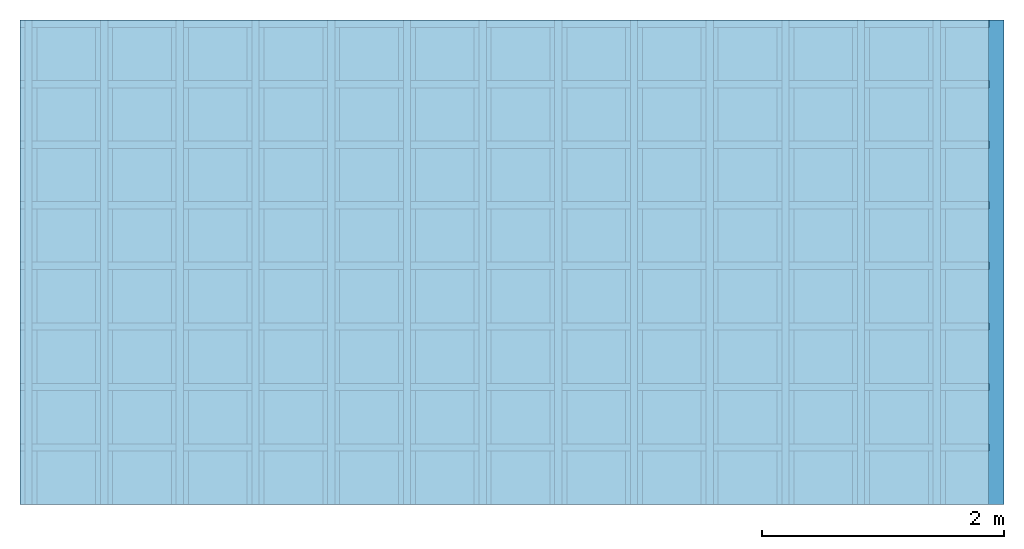
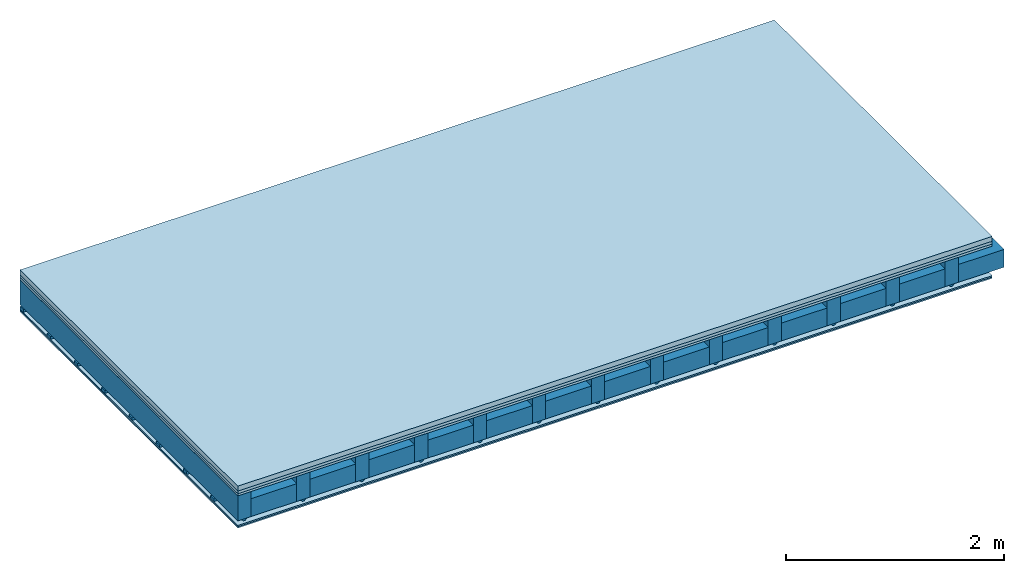
# One storey: 5 plates, 4 members, 1 element without a shape of its own.
"""IFC4 building model written with IfcOpenShell, lengths in metres."""

from ifc_helpers import new_model, si_unit, derived_unit, direction, frame, frame_2d, origin, origin_with_axes, place, context, project, spatial, polyline, rectangle, outline, extrude, material, layer, layer_set, type_object, element, aggregate, save


model = new_model("IFC4")

# Units and contexts
plan_context = context("Plan", 3, precision=1e-05, world=origin(), true_north=direction((0.0, 1.0)))
model_context = context("Model", 3, precision=1e-05, world=origin(), true_north=direction((0.0, 1.0)))
ifc_project = project(units=[si_unit("LENGTHUNIT", "METRE"), derived_unit("SOUNDPRESSUREUNIT", [(si_unit("PRESSUREUNIT", "PASCAL", prefix="MICRO"), 0)]), si_unit("ENERGYUNIT", "JOULE", prefix="MEGA"), si_unit("MASSUNIT", "GRAM", prefix="KILO"), derived_unit("THERMALTRANSMITTANCEUNIT", [(si_unit("POWERUNIT", "WATT"), 1), (si_unit("AREAUNIT", "SQUARE_METRE"), -1), (si_unit("THERMODYNAMICTEMPERATUREUNIT", "KELVIN"), -1)]), derived_unit("AREADENSITYUNIT", [(si_unit("MASSUNIT", "GRAM", prefix="KILO"), 1), (si_unit("AREAUNIT", "SQUARE_METRE"), -1)]), derived_unit("USERDEFINED", [(si_unit("ENERGYUNIT", "JOULE", prefix="MEGA"), 1), (si_unit("AREAUNIT", "SQUARE_METRE"), -1)])], contexts=[plan_context, model_context])

# Site, building, storey
site = spatial("IfcSite", under=ifc_project)
building_placement = place(None, origin())
building = spatial("IfcBuilding", under=site, at=building_placement)
storey_placement = place(building_placement, origin())
storey = spatial("IfcBuildingStorey", under=building, at=storey_placement)

# Slab, members, plates
ifc_material_1 = material(Category="04.005")
ifc_layer_1 = layer(ifc_material_1, 0.055, Name="On-material")
ifc_material_2 = material()
ifc_layer_2 = layer(ifc_material_2, 0.03, Name="Impact sound insulation")
ifc_material_3 = material(Category="07.001")
ifc_layer_3 = layer(ifc_material_3, 0.025, Name="Sub-floor")
ifc_material_4 = material(Name="of the art")
ifc_layer_4 = layer(ifc_material_4, 0.0, Name="Bond")
ifc_layer_5 = layer(None, 0.28, Name="Supporting structure")
ifc_material_5 = material(Name="no composite action")
ifc_layer_6 = layer(ifc_material_5, 0.0, Name="Bond")
ifc_layer_7 = layer(None, 0.02, Name="Coupling")
ifc_layer_8 = layer(None, 0.03, Name="Battens / profiles")
ifc_material_6 = material(Category="03.007")
ifc_layer_9 = layer(ifc_material_6, 0.015, Name="Ceiling covering 1st layer")
ifc_layer_10 = layer(ifc_material_6, 0.015, Name="Ceiling covering layer 2")
ifc_material_7 = material(Name="Glued joints")
ifc_layer_11 = layer(ifc_material_7, 0.0, Name="Surface / treatment")
ifc_layer_set = layer_set([ifc_layer_1, ifc_layer_2, ifc_layer_3, ifc_layer_4, ifc_layer_5, ifc_layer_6, ifc_layer_7, ifc_layer_8, ifc_layer_9, ifc_layer_10, ifc_layer_11])
slab_type = type_object("IfcSlabType", Name="A0127", PredefinedType="NOTDEFINED", material=ifc_layer_set)
slab_placement = place(None, frame((0.0, 0.0, 0.0), z_axis=(0.0, 0.0, -1.0), x_axis=(1.0, 0.0, 0.0)))
slab = element("IfcSlab", 1, at=slab_placement, inside=storey, type_object=slab_type, material=ifc_layer_set, Name="Slab #1")
ifc_material_8 = material()
member_1_placement = place(slab_placement, origin())
member_1 = element("IfcMember", 2, at=member_1_placement, material=ifc_material_8, Name="Supporting structure", context=plan_context, shape_type="SweptSolid", body=[
    extrude(rectangle(XDim=0.14, YDim=0.28, at=frame_2d((0.07, 0.14), x_axis=(1.0, 0.0))), frame((0.0, 4.0, 0.11), z_axis=(0.0, -1.0, 0.0), x_axis=(1.0, 0.0, 0.0)), (0.0, 0.0, 1.0), 4.0),
    extrude(rectangle(XDim=0.14, YDim=0.28, at=frame_2d((0.07, 0.14), x_axis=(1.0, 0.0))), frame((0.625, 4.0, 0.11), z_axis=(0.0, -1.0, 0.0), x_axis=(1.0, 0.0, 0.0)), (0.0, 0.0, 1.0), 4.0),
    extrude(rectangle(XDim=0.14, YDim=0.28, at=frame_2d((0.07, 0.14), x_axis=(1.0, 0.0))), frame((1.25, 4.0, 0.11), z_axis=(0.0, -1.0, 0.0), x_axis=(1.0, 0.0, 0.0)), (0.0, 0.0, 1.0), 4.0),
    extrude(rectangle(XDim=0.14, YDim=0.28, at=frame_2d((0.07, 0.14), x_axis=(1.0, 0.0))), frame((1.875, 4.0, 0.11), z_axis=(0.0, -1.0, 0.0), x_axis=(1.0, 0.0, 0.0)), (0.0, 0.0, 1.0), 4.0),
    extrude(rectangle(XDim=0.14, YDim=0.28, at=frame_2d((0.07, 0.14), x_axis=(1.0, 0.0))), frame((2.5, 4.0, 0.11), z_axis=(0.0, -1.0, 0.0), x_axis=(1.0, 0.0, 0.0)), (0.0, 0.0, 1.0), 4.0),
    extrude(rectangle(XDim=0.14, YDim=0.28, at=frame_2d((0.07, 0.14), x_axis=(1.0, 0.0))), frame((3.125, 4.0, 0.11), z_axis=(0.0, -1.0, 0.0), x_axis=(1.0, 0.0, 0.0)), (0.0, 0.0, 1.0), 4.0),
    extrude(rectangle(XDim=0.14, YDim=0.28, at=frame_2d((0.07, 0.14), x_axis=(1.0, 0.0))), frame((3.75, 4.0, 0.11), z_axis=(0.0, -1.0, 0.0), x_axis=(1.0, 0.0, 0.0)), (0.0, 0.0, 1.0), 4.0),
    extrude(rectangle(XDim=0.14, YDim=0.28, at=frame_2d((0.07, 0.14), x_axis=(1.0, 0.0))), frame((4.375, 4.0, 0.11), z_axis=(0.0, -1.0, 0.0), x_axis=(1.0, 0.0, 0.0)), (0.0, 0.0, 1.0), 4.0),
    extrude(rectangle(XDim=0.14, YDim=0.28, at=frame_2d((0.07, 0.14), x_axis=(1.0, 0.0))), frame((5.0, 4.0, 0.11), z_axis=(0.0, -1.0, 0.0), x_axis=(1.0, 0.0, 0.0)), (0.0, 0.0, 1.0), 4.0),
    extrude(rectangle(XDim=0.14, YDim=0.28, at=frame_2d((0.07, 0.14), x_axis=(1.0, 0.0))), frame((5.625, 4.0, 0.11), z_axis=(0.0, -1.0, 0.0), x_axis=(1.0, 0.0, 0.0)), (0.0, 0.0, 1.0), 4.0),
    extrude(rectangle(XDim=0.14, YDim=0.28, at=frame_2d((0.07, 0.14), x_axis=(1.0, 0.0))), frame((6.25, 4.0, 0.11), z_axis=(0.0, -1.0, 0.0), x_axis=(1.0, 0.0, 0.0)), (0.0, 0.0, 1.0), 4.0),
    extrude(rectangle(XDim=0.14, YDim=0.28, at=frame_2d((0.07, 0.14), x_axis=(1.0, 0.0))), frame((6.875, 4.0, 0.11), z_axis=(0.0, -1.0, 0.0), x_axis=(1.0, 0.0, 0.0)), (0.0, 0.0, 1.0), 4.0),
    extrude(rectangle(XDim=0.14, YDim=0.28, at=frame_2d((0.07, 0.14), x_axis=(1.0, 0.0))), frame((7.5, 4.0, 0.11), z_axis=(0.0, -1.0, 0.0), x_axis=(1.0, 0.0, 0.0)), (0.0, 0.0, 1.0), 4.0),
])
ifc_material_9 = material()
member_2_placement = place(slab_placement, origin())
member_2 = element("IfcMember", 3, at=member_2_placement, material=ifc_material_9, Name="Cavity", context=plan_context, shape_type="SweptSolid", body=[
    extrude(rectangle(XDim=0.485, YDim=0.2, at=frame_2d((0.2425, 0.1), x_axis=(1.0, 0.0))), frame((0.14, 4.0, 0.19), z_axis=(0.0, -1.0, 0.0), x_axis=(1.0, 0.0, 0.0)), (0.0, 0.0, 1.0), 4.0),
    extrude(rectangle(XDim=0.485, YDim=0.2, at=frame_2d((0.2425, 0.1), x_axis=(1.0, 0.0))), frame((0.765, 4.0, 0.19), z_axis=(0.0, -1.0, 0.0), x_axis=(1.0, 0.0, 0.0)), (0.0, 0.0, 1.0), 4.0),
    extrude(rectangle(XDim=0.485, YDim=0.2, at=frame_2d((0.2425, 0.1), x_axis=(1.0, 0.0))), frame((1.39, 4.0, 0.19), z_axis=(0.0, -1.0, 0.0), x_axis=(1.0, 0.0, 0.0)), (0.0, 0.0, 1.0), 4.0),
    extrude(rectangle(XDim=0.485, YDim=0.2, at=frame_2d((0.2425, 0.1), x_axis=(1.0, 0.0))), frame((2.015, 4.0, 0.19), z_axis=(0.0, -1.0, 0.0), x_axis=(1.0, 0.0, 0.0)), (0.0, 0.0, 1.0), 4.0),
    extrude(rectangle(XDim=0.485, YDim=0.2, at=frame_2d((0.2425, 0.1), x_axis=(1.0, 0.0))), frame((2.64, 4.0, 0.19), z_axis=(0.0, -1.0, 0.0), x_axis=(1.0, 0.0, 0.0)), (0.0, 0.0, 1.0), 4.0),
    extrude(rectangle(XDim=0.485, YDim=0.2, at=frame_2d((0.2425, 0.1), x_axis=(1.0, 0.0))), frame((3.265, 4.0, 0.19), z_axis=(0.0, -1.0, 0.0), x_axis=(1.0, 0.0, 0.0)), (0.0, 0.0, 1.0), 4.0),
    extrude(rectangle(XDim=0.485, YDim=0.2, at=frame_2d((0.2425, 0.1), x_axis=(1.0, 0.0))), frame((3.89, 4.0, 0.19), z_axis=(0.0, -1.0, 0.0), x_axis=(1.0, 0.0, 0.0)), (0.0, 0.0, 1.0), 4.0),
    extrude(rectangle(XDim=0.485, YDim=0.2, at=frame_2d((0.2425, 0.1), x_axis=(1.0, 0.0))), frame((4.515, 4.0, 0.19), z_axis=(0.0, -1.0, 0.0), x_axis=(1.0, 0.0, 0.0)), (0.0, 0.0, 1.0), 4.0),
    extrude(rectangle(XDim=0.485, YDim=0.2, at=frame_2d((0.2425, 0.1), x_axis=(1.0, 0.0))), frame((5.14, 4.0, 0.19), z_axis=(0.0, -1.0, 0.0), x_axis=(1.0, 0.0, 0.0)), (0.0, 0.0, 1.0), 4.0),
    extrude(rectangle(XDim=0.485, YDim=0.2, at=frame_2d((0.2425, 0.1), x_axis=(1.0, 0.0))), frame((5.765, 4.0, 0.19), z_axis=(0.0, -1.0, 0.0), x_axis=(1.0, 0.0, 0.0)), (0.0, 0.0, 1.0), 4.0),
    extrude(rectangle(XDim=0.485, YDim=0.2, at=frame_2d((0.2425, 0.1), x_axis=(1.0, 0.0))), frame((6.39, 4.0, 0.19), z_axis=(0.0, -1.0, 0.0), x_axis=(1.0, 0.0, 0.0)), (0.0, 0.0, 1.0), 4.0),
    extrude(rectangle(XDim=0.485, YDim=0.2, at=frame_2d((0.2425, 0.1), x_axis=(1.0, 0.0))), frame((7.015, 4.0, 0.19), z_axis=(0.0, -1.0, 0.0), x_axis=(1.0, 0.0, 0.0)), (0.0, 0.0, 1.0), 4.0),
    extrude(rectangle(XDim=0.485, YDim=0.2, at=frame_2d((0.2425, 0.1), x_axis=(1.0, 0.0))), frame((7.64, 4.0, 0.19), z_axis=(0.0, -1.0, 0.0), x_axis=(1.0, 0.0, 0.0)), (0.0, 0.0, 1.0), 4.0),
])
ifc_material_10 = material()
member_3_placement = place(slab_placement, origin())
member_3 = element("IfcMember", 4, at=member_3_placement, material=ifc_material_10, Name="Coupling", context=plan_context, shape_type="SweptSolid", body=[
    extrude(outline(polyline([(0.0, 0.0), (0.06, 0.0), (0.04, 0.02), (0.02, 0.02), (0.0, 0.0)])), frame((0.04, 4.0, 0.39), z_axis=(0.0, -1.0, 0.0), x_axis=(1.0, 0.0, 0.0)), (0.0, 0.0, 1.0), 4.0),
    extrude(outline(polyline([(0.0, 0.0), (0.06, 0.0), (0.04, 0.02), (0.02, 0.02), (0.0, 0.0)])), frame((0.665, 4.0, 0.39), z_axis=(0.0, -1.0, 0.0), x_axis=(1.0, 0.0, 0.0)), (0.0, 0.0, 1.0), 4.0),
    extrude(outline(polyline([(0.0, 0.0), (0.06, 0.0), (0.04, 0.02), (0.02, 0.02), (0.0, 0.0)])), frame((1.29, 4.0, 0.39), z_axis=(0.0, -1.0, 0.0), x_axis=(1.0, 0.0, 0.0)), (0.0, 0.0, 1.0), 4.0),
    extrude(outline(polyline([(0.0, 0.0), (0.06, 0.0), (0.04, 0.02), (0.02, 0.02), (0.0, 0.0)])), frame((1.915, 4.0, 0.39), z_axis=(0.0, -1.0, 0.0), x_axis=(1.0, 0.0, 0.0)), (0.0, 0.0, 1.0), 4.0),
    extrude(outline(polyline([(0.0, 0.0), (0.06, 0.0), (0.04, 0.02), (0.02, 0.02), (0.0, 0.0)])), frame((2.54, 4.0, 0.39), z_axis=(0.0, -1.0, 0.0), x_axis=(1.0, 0.0, 0.0)), (0.0, 0.0, 1.0), 4.0),
    extrude(outline(polyline([(0.0, 0.0), (0.06, 0.0), (0.04, 0.02), (0.02, 0.02), (0.0, 0.0)])), frame((3.165, 4.0, 0.39), z_axis=(0.0, -1.0, 0.0), x_axis=(1.0, 0.0, 0.0)), (0.0, 0.0, 1.0), 4.0),
    extrude(outline(polyline([(0.0, 0.0), (0.06, 0.0), (0.04, 0.02), (0.02, 0.02), (0.0, 0.0)])), frame((3.79, 4.0, 0.39), z_axis=(0.0, -1.0, 0.0), x_axis=(1.0, 0.0, 0.0)), (0.0, 0.0, 1.0), 4.0),
    extrude(outline(polyline([(0.0, 0.0), (0.06, 0.0), (0.04, 0.02), (0.02, 0.02), (0.0, 0.0)])), frame((4.415, 4.0, 0.39), z_axis=(0.0, -1.0, 0.0), x_axis=(1.0, 0.0, 0.0)), (0.0, 0.0, 1.0), 4.0),
    extrude(outline(polyline([(0.0, 0.0), (0.06, 0.0), (0.04, 0.02), (0.02, 0.02), (0.0, 0.0)])), frame((5.04, 4.0, 0.39), z_axis=(0.0, -1.0, 0.0), x_axis=(1.0, 0.0, 0.0)), (0.0, 0.0, 1.0), 4.0),
    extrude(outline(polyline([(0.0, 0.0), (0.06, 0.0), (0.04, 0.02), (0.02, 0.02), (0.0, 0.0)])), frame((5.665, 4.0, 0.39), z_axis=(0.0, -1.0, 0.0), x_axis=(1.0, 0.0, 0.0)), (0.0, 0.0, 1.0), 4.0),
    extrude(outline(polyline([(0.0, 0.0), (0.06, 0.0), (0.04, 0.02), (0.02, 0.02), (0.0, 0.0)])), frame((6.29, 4.0, 0.39), z_axis=(0.0, -1.0, 0.0), x_axis=(1.0, 0.0, 0.0)), (0.0, 0.0, 1.0), 4.0),
    extrude(outline(polyline([(0.0, 0.0), (0.06, 0.0), (0.04, 0.02), (0.02, 0.02), (0.0, 0.0)])), frame((6.915, 4.0, 0.39), z_axis=(0.0, -1.0, 0.0), x_axis=(1.0, 0.0, 0.0)), (0.0, 0.0, 1.0), 4.0),
    extrude(outline(polyline([(0.0, 0.0), (0.06, 0.0), (0.04, 0.02), (0.02, 0.02), (0.0, 0.0)])), frame((7.54, 4.0, 0.39), z_axis=(0.0, -1.0, 0.0), x_axis=(1.0, 0.0, 0.0)), (0.0, 0.0, 1.0), 4.0),
])
ifc_material_11 = material()
member_4_placement = place(slab_placement, origin())
member_4 = element("IfcMember", 5, at=member_4_placement, material=ifc_material_11, Name="Battens / profiles", context=plan_context, shape_type="SweptSolid", body=[
    extrude(rectangle(XDim=0.06, YDim=0.03, at=frame_2d((0.03, 0.015), x_axis=(1.0, 0.0))), frame((0.0, 0.0, 0.41), z_axis=(1.0, 0.0, 0.0), x_axis=(0.0, 1.0, 0.0)), (0.0, 0.0, 1.0), 8.0),
    extrude(rectangle(XDim=0.06, YDim=0.03, at=frame_2d((0.03, 0.015), x_axis=(1.0, 0.0))), frame((0.0, 0.5, 0.41), z_axis=(1.0, 0.0, 0.0), x_axis=(0.0, 1.0, 0.0)), (0.0, 0.0, 1.0), 8.0),
    extrude(rectangle(XDim=0.06, YDim=0.03, at=frame_2d((0.03, 0.015), x_axis=(1.0, 0.0))), frame((0.0, 1.0, 0.41), z_axis=(1.0, 0.0, 0.0), x_axis=(0.0, 1.0, 0.0)), (0.0, 0.0, 1.0), 8.0),
    extrude(rectangle(XDim=0.06, YDim=0.03, at=frame_2d((0.03, 0.015), x_axis=(1.0, 0.0))), frame((0.0, 1.5, 0.41), z_axis=(1.0, 0.0, 0.0), x_axis=(0.0, 1.0, 0.0)), (0.0, 0.0, 1.0), 8.0),
    extrude(rectangle(XDim=0.06, YDim=0.03, at=frame_2d((0.03, 0.015), x_axis=(1.0, 0.0))), frame((0.0, 2.0, 0.41), z_axis=(1.0, 0.0, 0.0), x_axis=(0.0, 1.0, 0.0)), (0.0, 0.0, 1.0), 8.0),
    extrude(rectangle(XDim=0.06, YDim=0.03, at=frame_2d((0.03, 0.015), x_axis=(1.0, 0.0))), frame((0.0, 2.5, 0.41), z_axis=(1.0, 0.0, 0.0), x_axis=(0.0, 1.0, 0.0)), (0.0, 0.0, 1.0), 8.0),
    extrude(rectangle(XDim=0.06, YDim=0.03, at=frame_2d((0.03, 0.015), x_axis=(1.0, 0.0))), frame((0.0, 3.0, 0.41), z_axis=(1.0, 0.0, 0.0), x_axis=(0.0, 1.0, 0.0)), (0.0, 0.0, 1.0), 8.0),
    extrude(rectangle(XDim=0.06, YDim=0.03, at=frame_2d((0.03, 0.015), x_axis=(1.0, 0.0))), frame((0.0, 3.5, 0.41), z_axis=(1.0, 0.0, 0.0), x_axis=(0.0, 1.0, 0.0)), (0.0, 0.0, 1.0), 8.0),
])
plate_1_placement = place(slab_placement, origin())
plate_1 = element("IfcPlate", 6, at=plate_1_placement, material=ifc_material_1, Name="On-material", context=plan_context, shape_type="SweptSolid", body=[
    extrude(rectangle(XDim=8.0, YDim=4.0, at=frame_2d((4.0, 2.0), x_axis=(1.0, 0.0))), origin_with_axes(), (0.0, 0.0, 1.0), 0.055),
])
plate_2_placement = place(slab_placement, origin())
plate_2 = element("IfcPlate", 7, at=plate_2_placement, material=ifc_material_2, Name="Impact sound insulation", context=plan_context, shape_type="SweptSolid", body=[
    extrude(rectangle(XDim=8.0, YDim=4.0, at=frame_2d((4.0, 2.0), x_axis=(1.0, 0.0))), frame((0.0, 0.0, 0.055), z_axis=(0.0, 0.0, 1.0), x_axis=(1.0, 0.0, 0.0)), (0.0, 0.0, 1.0), 0.03),
])
plate_3_placement = place(slab_placement, origin())
plate_3 = element("IfcPlate", 8, at=plate_3_placement, material=ifc_material_3, Name="Sub-floor", context=plan_context, shape_type="SweptSolid", body=[
    extrude(rectangle(XDim=8.0, YDim=4.0, at=frame_2d((4.0, 2.0), x_axis=(1.0, 0.0))), frame((0.0, 0.0, 0.085), z_axis=(0.0, 0.0, 1.0), x_axis=(1.0, 0.0, 0.0)), (0.0, 0.0, 1.0), 0.025),
])
plate_4_placement = place(slab_placement, origin())
plate_4 = element("IfcPlate", 9, at=plate_4_placement, material=ifc_material_6, Name="Ceiling covering 1st layer", context=plan_context, shape_type="SweptSolid", body=[
    extrude(rectangle(XDim=8.0, YDim=4.0, at=frame_2d((4.0, 2.0), x_axis=(1.0, 0.0))), frame((0.0, 0.0, 0.44), z_axis=(0.0, 0.0, 1.0), x_axis=(1.0, 0.0, 0.0)), (0.0, 0.0, 1.0), 0.015),
])
plate_5_placement = place(slab_placement, origin())
plate_5 = element("IfcPlate", 10, at=plate_5_placement, material=ifc_material_6, Name="Ceiling covering layer 2", context=plan_context, shape_type="SweptSolid", body=[
    extrude(rectangle(XDim=8.0, YDim=4.0, at=frame_2d((4.0, 2.0), x_axis=(1.0, 0.0))), frame((0.0, 0.0, 0.455), z_axis=(0.0, 0.0, 1.0), x_axis=(1.0, 0.0, 0.0)), (0.0, 0.0, 1.0), 0.015),
])
aggregate(slab, [plate_1, plate_2, plate_3, member_1, member_2, member_3, member_4, plate_4, plate_5])

save(model, "model.ifc")
